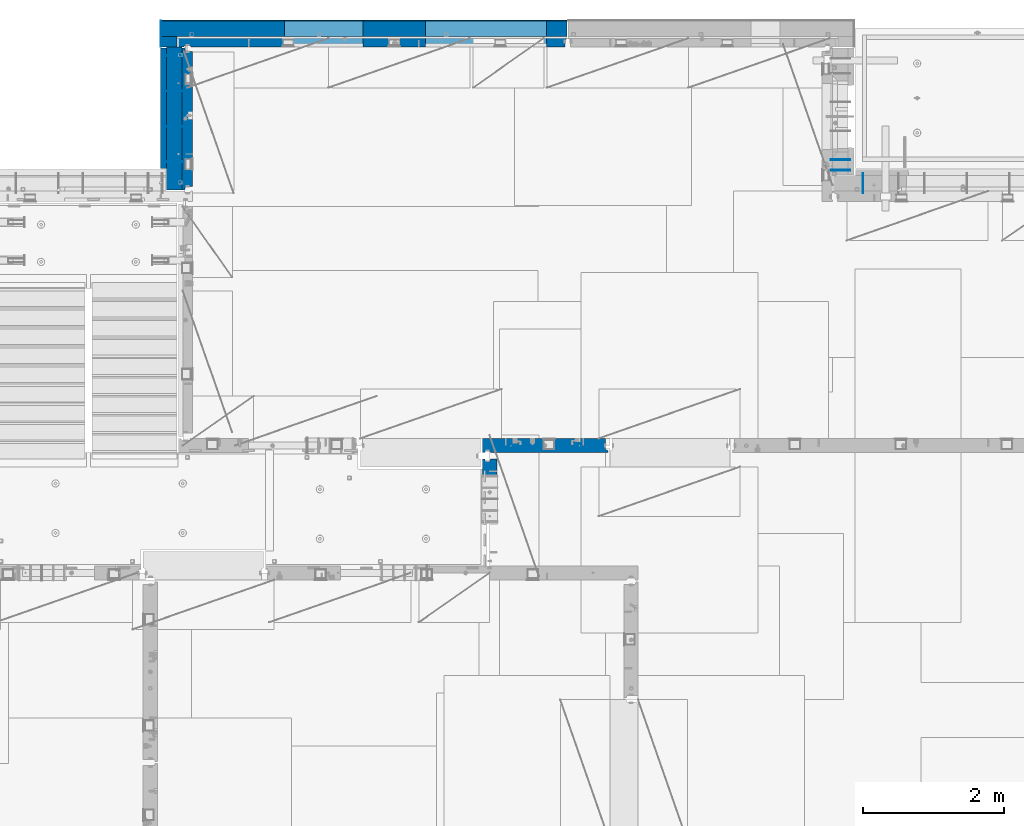
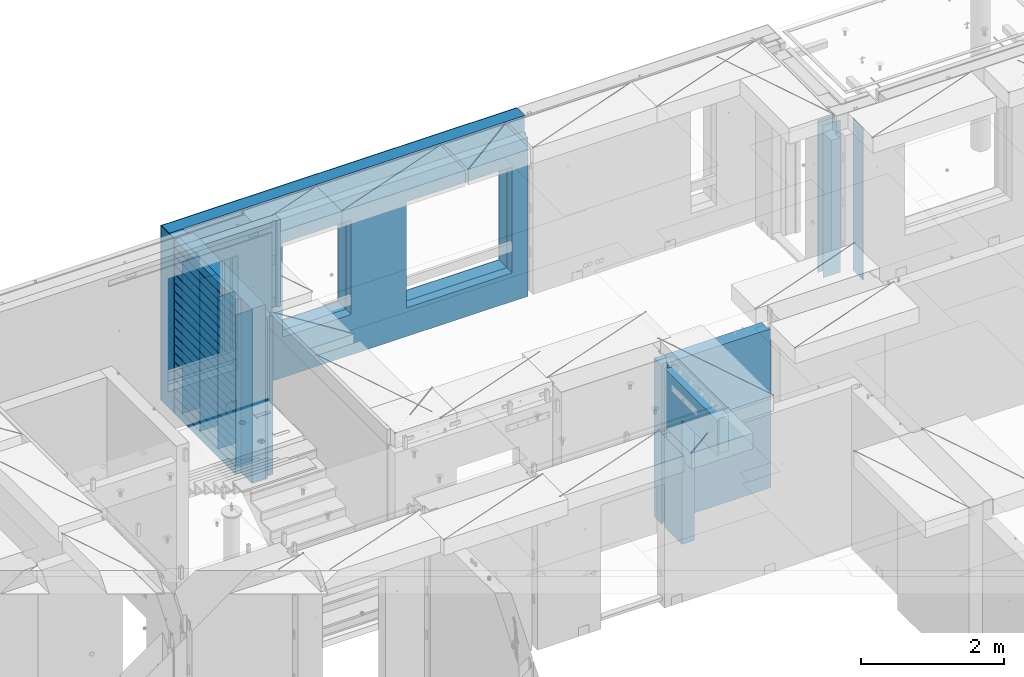
# One storey, part 239 of 349: 17 walls, 6 elements without a shape of their own.
"""IFC2X3 building model written with IfcOpenShell, lengths in millimetres."""

from ifc_helpers import new_model, si_unit, frame, origin_with_axes, place, context, subcontext, project, spatial, faceted_brep, material, type_object, element, aggregate, save


model = new_model("IFC2X3")

# Units and contexts
model_context = context("Model", 3, precision=1e-05, world=origin_with_axes())
body_context = subcontext(model_context, "Body", "Model", "MODEL_VIEW")
ifc_project = project(units=[si_unit("LENGTHUNIT", "METRE", prefix="MILLI"), si_unit("AREAUNIT", "SQUARE_METRE"), si_unit("VOLUMEUNIT", "CUBIC_METRE"), si_unit("MASSUNIT", "GRAM", prefix="KILO"), si_unit("TIMEUNIT", "SECOND"), si_unit("PLANEANGLEUNIT", "RADIAN"), si_unit("SOLIDANGLEUNIT", "STERADIAN"), si_unit("THERMODYNAMICTEMPERATUREUNIT", "DEGREE_CELSIUS"), si_unit("LUMINOUSINTENSITYUNIT", "LUMEN")], contexts=[model_context])

# Site, building, storey
site_placement = place(None, origin_with_axes())
site = spatial("IfcSite", under=ifc_project, at=site_placement, CompositionType="ELEMENT")
building_placement = place(site_placement, origin_with_axes())
building = spatial("IfcBuilding", under=site, at=building_placement, CompositionType="ELEMENT")
storey_placement = place(building_placement, origin_with_axes())
storey = spatial("IfcBuildingStorey", under=building, at=storey_placement, Name="4", CompositionType="ELEMENT", Elevation=0.0)

# Assembly, walls
assembly_1_placement = place(storey_placement, origin_with_axes())
assembly_1 = element("IfcElementAssembly", 1, at=assembly_1_placement, inside=storey, AssemblyPlace="NOTDEFINED", PredefinedType="REINFORCEMENT_UNIT")
ifc_material_1 = material(Name="Undefined")
wall_type_1 = type_object("IfcWallType", PredefinedType="NOTDEFINED")
wall_1_placement = place(assembly_1_placement, frame((22290.0, 22495.0, 92110.0), z_axis=(0.0, 0.0, 1.0), x_axis=(-1.0, 3.00000001838171e-08, 0.0)))
wall_1 = element("IfcWall", 2, at=wall_1_placement, type_object=wall_type_1, material=ifc_material_1, Name="(PD)", context=body_context, shape_type="Brep", body=[
    faceted_brep([(0.0, 5.0, -1300.0), (0.0, 5.0, 1300.0), (280.0, 5.0, 1300.0), (280.0, 5.0, -1300.0), (0.0, -5.0, 1300.0), (280.0, -5.0, 1300.0), (0.0, -5.0, -1300.0), (280.0, -5.0, -1300.0)], [[[0, 1, 2, 3]], [[1, 4, 5, 2]], [[4, 6, 7, 5]], [[6, 0, 3, 7]], [[5, 7, 3, 2]], [[6, 4, 1, 0]]]),
])
wall_2_placement = place(assembly_1_placement, frame((22290.0, 21995.0, 92110.0), z_axis=(0.0, 0.0, 1.0), x_axis=(-1.0, 3.00000001838171e-08, 0.0)))
wall_2 = element("IfcWall", 3, at=wall_2_placement, type_object=wall_type_1, material=ifc_material_1, Name="(PD)", context=body_context, shape_type="Brep", body=[
    faceted_brep([(0.0, 5.0, -1300.0), (0.0, 5.0, 1300.0), (280.0, 5.0, 1300.0), (280.0, 5.0, -1300.0), (0.0, -5.0, 1300.0), (280.0, -5.0, 1300.0), (0.0, -5.0, -1300.0), (280.0, -5.0, -1300.0)], [[[0, 1, 2, 3]], [[1, 4, 5, 2]], [[4, 6, 7, 5]], [[6, 0, 3, 7]], [[5, 7, 3, 2]], [[6, 4, 1, 0]]]),
])
wall_3_placement = place(assembly_1_placement, frame((22290.0, 21495.0, 92110.0), z_axis=(0.0, 0.0, 1.0), x_axis=(-1.0, 3.00000001838171e-08, 0.0)))
wall_3 = element("IfcWall", 4, at=wall_3_placement, type_object=wall_type_1, material=ifc_material_1, Name="(PD)", context=body_context, shape_type="Brep", body=[
    faceted_brep([(0.0, 5.0, -1300.0), (0.0, 5.0, 1300.0), (280.0, 5.0, 1300.0), (280.0, 5.0, -1300.0), (0.0, -5.0, 1300.0), (280.0, -5.0, 1300.0), (0.0, -5.0, -1300.0), (280.0, -5.0, -1300.0)], [[[0, 1, 2, 3]], [[1, 4, 5, 2]], [[4, 6, 7, 5]], [[6, 0, 3, 7]], [[5, 7, 3, 2]], [[6, 4, 1, 0]]]),
])

# Assembly, wall
assembly_2_placement = place(storey_placement, origin_with_axes())
assembly_2 = element("IfcElementAssembly", 5, at=assembly_2_placement, inside=storey, AssemblyPlace="NOTDEFINED", PredefinedType="REINFORCEMENT_UNIT")
wall_4_placement = place(assembly_2_placement, frame((31890.0, 20549.9951872276, 92115.0), z_axis=(0.0, 0.0, 1.0), x_axis=(0.0, 1.0, 0.0)))
wall_4 = element("IfcWall", 6, at=wall_4_placement, type_object=wall_type_1, material=ifc_material_1, Name="(PD)", context=body_context, shape_type="Brep", body=[
    faceted_brep([(0.0, 5.0, -1300.0), (0.0, 5.0, 1300.0), (280.0, 5.0, 1300.0), (280.0, 5.0, -1300.0), (0.0, -5.0, 1300.0), (280.0, -5.0, 1300.0), (0.0, -5.0, -1300.0), (280.0, -5.0, -1300.0)], [[[0, 1, 2, 3]], [[1, 4, 5, 2]], [[4, 6, 7, 5]], [[6, 0, 3, 7]], [[5, 7, 3, 2]], [[6, 4, 1, 0]]]),
])
aggregate(assembly_2, [wall_4])

# Assembly, walls
assembly_3_placement = place(storey_placement, origin_with_axes())
assembly_3 = element("IfcElementAssembly", 7, at=assembly_3_placement, inside=storey, AssemblyPlace="NOTDEFINED", PredefinedType="REINFORCEMENT_UNIT")
wall_5_placement = place(assembly_3_placement, frame((31429.9951872276, 20875.0, 92115.0), z_axis=(0.0, 0.0, 1.0), x_axis=(1.0, 0.0, 0.0)))
wall_5 = element("IfcWall", 8, at=wall_5_placement, type_object=wall_type_1, material=ifc_material_1, Name="(PD)", context=body_context, shape_type="Brep", body=[
    faceted_brep([(0.0, 5.0, -1300.0), (0.0, 5.0, 1300.0), (280.0, 5.0, 1300.0), (280.0, 5.0, -1300.0), (0.0, -5.0, 1300.0), (280.0, -5.0, 1300.0), (0.0, -5.0, -1300.0), (280.0, -5.0, -1300.0)], [[[0, 1, 2, 3]], [[1, 4, 5, 2]], [[4, 6, 7, 5]], [[6, 0, 3, 7]], [[5, 7, 3, 2]], [[6, 4, 1, 0]]]),
])
wall_6_placement = place(assembly_3_placement, frame((31429.9951872276, 21025.0, 92115.0), z_axis=(0.0, 0.0, 1.0), x_axis=(1.0, 0.0, 0.0)))
wall_6 = element("IfcWall", 9, at=wall_6_placement, type_object=wall_type_1, material=ifc_material_1, Name="(PD)", context=body_context, shape_type="Brep", body=[
    faceted_brep([(0.0, 5.0, -1300.0), (0.0, 5.0, 1300.0), (280.0, 5.0, 1300.0), (280.0, 5.0, -1300.0), (0.0, -5.0, 1300.0), (280.0, -5.0, 1300.0), (0.0, -5.0, -1300.0), (280.0, -5.0, -1300.0)], [[[0, 1, 2, 3]], [[1, 4, 5, 2]], [[4, 6, 7, 5]], [[6, 0, 3, 7]], [[5, 7, 3, 2]], [[6, 4, 1, 0]]]),
])
aggregate(assembly_3, [wall_5, wall_6])

# Wall
wall_7_placement = place(assembly_1_placement, frame((22290.0, 20995.0, 92110.0), z_axis=(0.0, 0.0, 1.0), x_axis=(-1.0, 3.00000001838171e-08, 0.0)))
wall_7 = element("IfcWall", 10, at=wall_7_placement, type_object=wall_type_1, material=ifc_material_1, Name="(PD)", context=body_context, shape_type="Brep", body=[
    faceted_brep([(0.0, 5.0, -1300.0), (0.0, 5.0, 1300.0), (280.0, 5.0, 1300.0), (280.0, 5.0, -1300.0), (0.0, -5.0, 1300.0), (280.0, -5.0, 1300.0), (0.0, -5.0, -1300.0), (280.0, -5.0, -1300.0)], [[[0, 1, 2, 3]], [[1, 4, 5, 2]], [[4, 6, 7, 5]], [[6, 0, 3, 7]], [[5, 7, 3, 2]], [[6, 4, 1, 0]]]),
])

# Assembly, wall
assembly_4_placement = place(storey_placement, origin_with_axes())
assembly_4 = element("IfcElementAssembly", 11, at=assembly_4_placement, inside=storey, AssemblyPlace="NOTDEFINED", PredefinedType="REINFORCEMENT_UNIT")
ifc_material_2 = material(Name="CONCRETE/C25/30")
wall_type_2 = type_object("IfcWallType", PredefinedType="NOTDEFINED")
wall_8_placement = place(assembly_4_placement, frame((26510.0014364077, 16980.0, 92112.5), z_axis=(0.0, 0.0, 1.0), x_axis=(1.0, 0.0, 0.0)))
wall_8 = element("IfcWall", 12, at=wall_8_placement, type_object=wall_type_2, material=ifc_material_2, context=body_context, shape_type="Brep", body=[
    faceted_brep([(1739.99847412109, 100.0, 1357.5), (1739.99847412109, -57.0, 1357.5), (1739.99847412109, -57.0, -1357.5), (1739.99847412109, 100.0, -1357.5), (1769.99847412109, -70.0, 1357.5), (1769.99847412109, -70.0, -1357.5), (0.0, -100.0, -1357.5), (0.0, -100.0, 1357.5), (0.0, 100.0, 1357.5), (0.0, 100.0, -1357.5), (29.998563592264, -100.0, -1357.5), (29.998563592264, -100.0, 1357.5), (29.998563592264, -80.0008544921875, -1357.5), (29.998563592264, -80.0008544921875, 1357.5), (109.998563592264, -80.0008544921875, -1357.5), (109.998563592264, -80.0008544921875, 1357.5), (109.998563592264, -100.0, -1357.5), (109.998563592264, -100.0, 1357.5), (1769.99847412109, -100.0, -1357.5), (1769.99847412109, -100.0, 1357.5)], [[[0, 1, 2, 3]], [[4, 5, 2, 1]], [[6, 7, 8, 9]], [[7, 6, 10, 11]], [[11, 10, 12, 13]], [[13, 12, 14, 15]], [[15, 14, 16, 17]], [[18, 19, 17, 16]], [[0, 8, 7, 11, 13, 15, 17, 19, 4, 1]], [[9, 8, 0, 3]], [[18, 16, 14, 12, 10, 6, 9, 3, 2, 5]], [[19, 18, 5, 4]]]),
])
aggregate(assembly_4, [wall_8])

assembly_5_placement = place(storey_placement, origin_with_axes())
assembly_5 = element("IfcElementAssembly", 13, at=assembly_5_placement, inside=storey, AssemblyPlace="NOTDEFINED", PredefinedType="REINFORCEMENT_UNIT")
wall_9_placement = place(assembly_5_placement, frame((26609.9991475894, 15280.0004107749, 92112.5), z_axis=(0.0, 0.0, 1.0), x_axis=(0.0, 1.0, 0.0)))
wall_9 = element("IfcWall", 14, at=wall_9_placement, type_object=wall_type_2, material=ifc_material_2, context=body_context, shape_type="Brep", body=[
    faceted_brep([(1509.99949975397, 70.0, 1357.5), (1489.99949975397, 70.0, 1357.5), (1489.99949975397, 70.0, -1357.5), (1509.99949975397, 70.0, -1357.5), (1489.99949975397, -10.0, 1357.5), (1489.99949975397, -10.0, -1357.5), (1509.99949975397, -10.0, 1357.5), (1509.99949975397, -10.0, -1357.5), (29.9995892251427, 70.0, 1357.5), (29.9995892251427, 70.0, 762.5), (59.9995892251427, 57.0, 762.5), (59.9995892251427, 57.0, 1357.5), (29.9995892251427, 100.0, 1357.5), (29.9995892251427, 100.0, 762.5), (1509.99949975397, 100.0, 1357.5), (1509.99949975397, 100.0, -1357.5), (1019.99979369292, 100.0, -1357.5), (1019.99979369292, 100.0, 762.5), (1019.99979369292, -100.0, 762.5), (1019.99979369292, -100.0, -1357.5), (59.9995892251427, -100.0, 762.5), (59.9995892251427, -100.0, 1357.5), (1509.99949975397, -100.0, -1357.5), (1509.99949975397, -100.0, 1357.5)], [[[0, 1, 2, 3]], [[4, 5, 2, 1]], [[6, 7, 5, 4]], [[8, 9, 10, 11]], [[12, 13, 9, 8]], [[12, 14, 15, 16, 17, 13]], [[18, 17, 16, 19]], [[9, 13, 17, 18, 20, 10]], [[21, 11, 10, 20]], [[18, 19, 22, 23, 21, 20]], [[1, 0, 14, 12, 8, 11, 21, 23, 6, 4]], [[15, 14, 0, 3]], [[22, 19, 16, 15, 3, 2, 5, 7]], [[23, 22, 7, 6]]]),
])
aggregate(assembly_5, [wall_9])

# Wall
ifc_material_3 = material(Name="COS5gt")
wall_type_3 = type_object("IfcWallType", PredefinedType="NOTDEFINED")
wall_10_placement = place(assembly_1_placement, frame((22150.0, 20595.0, 92247.5), z_axis=(0.0, 0.0, 1.0), x_axis=(0.0, 1.0, 0.0)))
wall_10 = element("IfcWall", 15, at=wall_10_placement, type_object=wall_type_3, material=ifc_material_3, context=body_context, shape_type="Brep", body=[
    faceted_brep([(0.0, 110.0, -1492.5), (0.0, 110.0, 1492.5), (2025.0, 110.0, 1492.5), (2025.0, 110.0, -1492.5), (0.0, -110.0, 1492.5), (2025.0, -110.0, 1492.5), (0.0, -110.0, -1492.5), (2025.0, -110.0, -1492.5)], [[[0, 1, 2, 3]], [[1, 4, 5, 2]], [[4, 6, 7, 5]], [[6, 0, 3, 7]], [[5, 7, 3, 2]], [[6, 4, 1, 0]]]),
])

# Assembly, walls
assembly_6_placement = place(storey_placement, origin_with_axes())
assembly_6 = element("IfcElementAssembly", 16, at=assembly_6_placement, inside=storey, AssemblyPlace="NOTDEFINED", PredefinedType="REINFORCEMENT_UNIT")
ifc_material_4 = material()
wall_11_placement = place(assembly_6_placement, frame((22075.0, 22620.0, 92247.5), z_axis=(0.0, 0.0, 1.0), x_axis=(0.0, 1.0, 0.0)))
wall_11 = element("IfcWall", 17, at=wall_11_placement, type_object=wall_type_3, material=ifc_material_4, context=body_context, shape_type="Brep", body=[
    faceted_brep([(0.0, 110.0, -1492.5), (0.0, 110.0, 1492.5), (150.0, 110.0, 1492.5), (150.0, 110.0, -1492.5), (0.0, -110.0, 1492.5), (150.0, -110.0, 1492.5), (0.0, -110.0, -1492.5), (150.0, -110.0, -1492.5)], [[[0, 1, 2, 3]], [[1, 4, 5, 2]], [[4, 6, 7, 5]], [[6, 0, 3, 7]], [[5, 7, 3, 2]], [[6, 4, 1, 0]]]),
])
wall_12_placement = place(assembly_6_placement, frame((22260.0, 22880.0, 92247.5), z_axis=(0.0, 0.0, 1.0), x_axis=(1.0, 0.0, 0.0)))
wall_12 = element("IfcWall", 18, at=wall_12_placement, type_object=wall_type_3, material=ifc_material_4, context=body_context, shape_type="Brep", body=[
    faceted_brep([(-295.0, 110.0, 1492.5), (-295.0, -110.0, 1492.5), (5445.0, -110.0, 1492.5), (5445.0, 110.0, 1492.5), (-295.0, -110.0, -1492.5), (-295.0, 110.0, -1492.5), (5445.0, 110.0, -1492.5), (5445.0, -110.0, -1492.5), (3445.00100868184, 110.0, -1002.5), (5155.00100868184, 110.0, -1002.5), (5155.00100868184, 110.0, 807.5), (3445.00100868184, 110.0, 807.5), (1444.99910133321, 110.0, -802.5), (2554.99910133321, 110.0, -802.5), (2554.99910133321, 110.0, 807.5), (1444.99910133321, 110.0, 807.5), (1444.99910133321, -110.0, -802.5), (2554.99910133321, -110.0, -802.5), (1444.99910133321, -110.0, 807.5), (2554.99910133321, -110.0, 807.5), (3445.00100868184, -110.0, -1002.5), (3445.00100868184, -110.0, 807.5), (5155.00100868184, -110.0, 807.5), (5155.00100868184, -110.0, -1002.5)], [[[0, 1, 2, 3]], [[4, 1, 0, 5]], [[4, 5, 6, 7]], [[2, 7, 6, 3]], [[5, 0, 3, 6], [8, 9, 10, 11], [12, 13, 14, 15]], [[12, 16, 17, 13]], [[15, 18, 16, 12]], [[14, 19, 18, 15]], [[13, 17, 19, 14]], [[1, 4, 7, 2], [20, 21, 22, 23], [16, 18, 19, 17]], [[10, 22, 21, 11]], [[9, 23, 22, 10]], [[8, 20, 23, 9]], [[11, 21, 20, 8]]]),
])

# Wall
ifc_material_5 = material(Name="CONCRETE/C30/37")
wall_type_4 = type_object("IfcWallType", PredefinedType="NOTDEFINED")
wall_13_placement = place(assembly_1_placement, frame((21997.5, 20900.0, 92247.5), z_axis=(0.0, 0.0, 1.0), x_axis=(0.0, 1.0, 0.0)))
wall_13 = element("IfcWall", 19, at=wall_13_placement, type_object=wall_type_4, material=ifc_material_5, context=body_context, shape_type="Brep", body=[
    faceted_brep([(1705.0, 42.5, -1357.0), (0.0, 42.5, -1357.00000005524), (0.0, 32.4999992507037, -1355.00000000074), (1705.0, 32.5, -1355.0), (1705.0, 32.5, -1345.0), (0.0, 32.4999991127006, -1344.99999959956), (0.0, 42.5, -1343.00000011075), (1705.0, 42.5, -1343.0), (0.0, -42.5, -1492.5), (0.0, 42.5, -1492.5), (1705.0, 42.5, -1492.5), (1705.0, -42.5, -1492.5), (0.0, -42.5, 1492.5), (1705.0, -42.5, 1492.5), (0.0, 42.5, 1492.5), (1705.0, 42.5, 1492.5), (1705.0, 42.5, 1357.0), (0.0, 42.5, 1356.99999988925), (1705.0, 32.5, 1355.0), (-3.63797880709171e-12, 32.4999991127006, 1355.00000040044), (1705.0, 32.5, 1345.0), (-3.63797880709171e-12, 32.4999992507037, 1344.99999999926), (1705.0, 42.5, 1343.0), (0.0, 42.5, 1342.99999994476), (1705.0, 42.5, 1207.0), (0.0, 42.5, 1206.99999988925), (1705.0, 32.5, 1205.0), (0.0, 32.4999991127006, 1205.00000040044), (1705.0, 32.5, 1195.0), (0.0, 32.4999992507037, 1194.99999999926), (1705.0, 42.5, 1193.0), (0.0, 42.5, 1192.99999994476), (1705.0, 42.5, 1057.0), (0.0, 42.5, 1056.99999988925), (1705.0, 32.5, 1055.0), (0.0, 32.4999991127006, 1055.00000040044), (1705.0, 32.5, 1045.0), (0.0, 32.4999992507037, 1044.99999999926), (1705.0, 42.5, 1043.0), (0.0, 42.5, 1042.99999994476), (1705.0, 42.5, 907.0), (0.0, 42.5, 906.999999889245), (1705.0, 32.5, 905.0), (0.0, 32.4999991127006, 905.00000040044), (1705.0, 32.5, 895.0), (0.0, 32.4999992507037, 894.999999999258), (1705.0, 42.5, 893.0), (0.0, 42.5, 892.999999944761), (1705.0, 42.5, 757.0), (0.0, 42.5, 756.999999889245), (1705.0, 32.5, 755.0), (0.0, 32.4999991127006, 755.00000040044), (1705.0, 32.5, 745.0), (0.0, 32.4999992507037, 744.999999999258), (1705.0, 42.5, 743.0), (0.0, 42.5, 742.999999944761), (1705.0, 42.5, 607.0), (0.0, 42.5, 606.999999889245), (1705.0, 32.5, 605.0), (3.63797880709171e-12, 32.4999991127006, 605.00000040044), (1705.0, 32.5, 595.0), (3.63797880709171e-12, 32.4999992507037, 594.999999999258), (1705.0, 42.5, 593.0), (0.0, 42.5, 592.999999944761), (1705.0, 42.5, 457.0), (0.0, 42.5, 456.999999889245), (1705.0, 32.5, 455.0), (0.0, 32.4999991127006, 455.00000040044), (1705.0, 32.5, 445.0), (0.0, 32.4999992507037, 444.999999999258), (1705.0, 42.5, 443.0), (0.0, 42.5, 442.999999944761), (1705.0, 42.5, 307.0), (0.0, 42.5, 306.999999889245), (1705.0, 32.5, 305.0), (-3.63797880709171e-12, 32.4999991127006, 305.00000040044), (1705.0, 32.5, 295.0), (-3.63797880709171e-12, 32.4999992507037, 294.999999999258), (1705.0, 42.5, 293.0), (0.0, 42.5, 292.999999944761), (1705.0, 42.5, 157.0), (0.0, 42.5, 156.999999889245), (1705.0, 32.5, 155.0), (-3.63797880709171e-12, 32.4999991127006, 155.00000040044), (1705.0, 32.5, 145.0), (-3.63797880709171e-12, 32.4999992507037, 144.999999999258), (1705.0, 42.5, 143.0), (0.0, 42.5, 142.999999944761), (1705.0, 42.5, 7.0), (0.0, 42.5, 6.99999988924537), (1705.0, 32.5, 5.0), (0.0, 32.4999991127006, 5.0000004004396), (1705.0, 32.5, -5.0), (0.0, 32.4999992507037, -5.00000000074215), (1705.0, 42.5, -7.0), (0.0, 42.5, -7.00000005523907), (1705.0, 42.5, -143.0), (0.0, 42.5, -143.000000110755), (1705.0, 32.5, -145.0), (3.63797880709171e-12, 32.4999991127006, -144.99999959956), (1705.0, 32.5, -155.0), (3.63797880709171e-12, 32.4999992507037, -155.000000000742), (1705.0, 42.5, -157.0), (0.0, 42.5, -157.000000055239), (1705.0, 42.5, -293.0), (0.0, 42.5, -293.000000110755), (1705.0, 32.5, -295.0), (0.0, 32.4999991127006, -294.99999959956), (1705.0, 32.5, -305.0), (0.0, 32.4999992507037, -305.000000000742), (1705.0, 42.5, -307.0), (0.0, 42.5, -307.000000055239), (1705.0, 42.5, -443.0), (0.0, 42.5, -443.000000110755), (1705.0, 32.5, -445.0), (0.0, 32.4999991127006, -444.99999959956), (1705.0, 32.5, -455.0), (0.0, 32.4999992507037, -455.000000000742), (1705.0, 42.5, -457.0), (0.0, 42.5, -457.000000055239), (1705.0, 42.5, -593.0), (0.0, 42.5, -593.000000110755), (1705.0, 32.5, -595.0), (3.63797880709171e-12, 32.4999991127006, -594.99999959956), (1705.0, 32.5, -605.0), (3.63797880709171e-12, 32.4999992507037, -605.000000000742), (1705.0, 42.5, -607.0), (0.0, 42.5, -607.000000055239), (1705.0, 42.5, -743.0), (0.0, 42.5, -743.000000110755), (1705.0, 32.5, -745.0), (0.0, 32.4999991127006, -744.99999959956), (1705.0, 32.5, -755.0), (0.0, 32.4999992507037, -755.000000000742), (1705.0, 42.5, -757.0), (0.0, 42.5, -757.000000055239), (1705.0, 42.5, -893.0), (0.0, 42.5, -893.000000110755), (1705.0, 32.5, -895.0), (0.0, 32.4999991127006, -894.99999959956), (1705.0, 32.5, -905.0), (0.0, 32.4999992507037, -905.000000000742), (1705.0, 42.5, -907.0), (0.0, 42.5, -907.000000055239), (1705.0, 42.5, -1043.0), (0.0, 42.5, -1043.00000011075), (1705.0, 32.5, -1045.0), (0.0, 32.4999991127006, -1044.99999959956), (1705.0, 32.5, -1055.0), (0.0, 32.4999992507037, -1055.00000000074), (1705.0, 42.5, -1057.0), (0.0, 42.5, -1057.00000005524), (1705.0, 42.5, -1193.0), (0.0, 42.5, -1193.00000011075), (1705.0, 32.5, -1195.0), (0.0, 32.4999991127006, -1194.99999959956), (1705.0, 32.5, -1205.0), (0.0, 32.4999992507037, -1205.00000000074), (1705.0, 42.5, -1207.0), (0.0, 42.5, -1207.00000005524)], [[[0, 1, 2, 3]], [[4, 5, 6, 7]], [[3, 2, 5, 4]], [[8, 9, 10, 11]], [[12, 8, 11, 13]], [[14, 12, 13, 15]], [[14, 15, 16, 17]], [[18, 19, 17, 16]], [[20, 21, 19, 18]], [[22, 23, 21, 20]], [[24, 25, 23, 22]], [[26, 27, 25, 24]], [[28, 29, 27, 26]], [[30, 31, 29, 28]], [[32, 33, 31, 30]], [[34, 35, 33, 32]], [[36, 37, 35, 34]], [[38, 39, 37, 36]], [[40, 41, 39, 38]], [[42, 43, 41, 40]], [[44, 45, 43, 42]], [[46, 47, 45, 44]], [[48, 49, 47, 46]], [[50, 51, 49, 48]], [[52, 53, 51, 50]], [[54, 55, 53, 52]], [[56, 57, 55, 54]], [[58, 59, 57, 56]], [[60, 61, 59, 58]], [[62, 63, 61, 60]], [[64, 65, 63, 62]], [[66, 67, 65, 64]], [[68, 69, 67, 66]], [[70, 71, 69, 68]], [[72, 73, 71, 70]], [[74, 75, 73, 72]], [[76, 77, 75, 74]], [[78, 79, 77, 76]], [[80, 81, 79, 78]], [[82, 83, 81, 80]], [[84, 85, 83, 82]], [[86, 87, 85, 84]], [[88, 89, 87, 86]], [[90, 91, 89, 88]], [[92, 93, 91, 90]], [[94, 95, 93, 92]], [[96, 97, 95, 94]], [[98, 99, 97, 96]], [[100, 101, 99, 98]], [[102, 103, 101, 100]], [[104, 105, 103, 102]], [[106, 107, 105, 104]], [[108, 109, 107, 106]], [[110, 111, 109, 108]], [[112, 113, 111, 110]], [[114, 115, 113, 112]], [[116, 117, 115, 114]], [[118, 119, 117, 116]], [[120, 121, 119, 118]], [[122, 123, 121, 120]], [[124, 125, 123, 122]], [[126, 127, 125, 124]], [[128, 129, 127, 126]], [[130, 131, 129, 128]], [[132, 133, 131, 130]], [[134, 135, 133, 132]], [[136, 137, 135, 134]], [[138, 139, 137, 136]], [[140, 141, 139, 138]], [[142, 143, 141, 140]], [[144, 145, 143, 142]], [[146, 147, 145, 144]], [[148, 149, 147, 146]], [[150, 151, 149, 148]], [[152, 153, 151, 150]], [[154, 155, 153, 152]], [[156, 157, 155, 154]], [[158, 159, 157, 156]], [[7, 6, 159, 158]], [[21, 23, 25, 27, 29, 31, 33, 35, 37, 39, 41, 43, 45, 47, 49, 51, 53, 55, 57, 59, 61, 63, 65, 67, 69, 71, 73, 75, 77, 79, 81, 83, 85, 87, 89, 91, 93, 95, 97, 99, 101, 103, 105, 107, 109, 111, 113, 115, 117, 119, 121, 123, 125, 127, 129, 131, 133, 135, 137, 139, 141, 143, 145, 147, 149, 151, 153, 155, 157, 159, 6, 5, 2, 1, 9, 8, 12, 14, 17, 19]], [[10, 9, 1, 0]], [[15, 13, 11, 10, 0, 3, 4, 7, 158, 156, 154, 152, 150, 148, 146, 144, 142, 140, 138, 136, 134, 132, 130, 128, 126, 124, 122, 120, 118, 116, 114, 112, 110, 108, 106, 104, 102, 100, 98, 96, 94, 92, 90, 88, 86, 84, 82, 80, 78, 76, 74, 72, 70, 68, 66, 64, 62, 60, 58, 56, 54, 52, 50, 48, 46, 44, 42, 40, 38, 36, 34, 32, 30, 28, 26, 24, 22, 20, 18, 16]]]),
])

wall_type_5 = type_object("IfcWallType", PredefinedType="NOTDEFINED")
wall_14_placement = place(assembly_6_placement, frame((22185.0, 22695.0, 92112.5), z_axis=(0.0, 0.0, 1.0), x_axis=(1.0, 0.0, 0.0)))
wall_14 = element("IfcWall", 20, at=wall_14_placement, type_object=wall_type_5, material=ifc_material_2, context=body_context, shape_type="Brep", body=[
    faceted_brep([(3520.00100868184, 75.0, 942.5), (3520.00100868184, -75.0000008199713, 942.5), (3520.00100868184, -75.0000000602631, -867.5), (3520.00100868184, 75.0, -867.5), (5230.00100868184, -74.9999996918959, -867.5), (5230.00100868184, 75.0, -867.5), (5230.00100868184, -75.0000004516041, 942.5), (5230.00100868184, 75.0, 942.5), (5490.0, -75.0, 1357.5), (5490.0, -75.0, -1357.5), (5490.0, 24.9999980926514, -1357.5), (5490.0, 24.9999980926514, 1357.5), (5520.0, 45.0, 1357.5), (5520.0, 75.0, 1357.5), (0.0, 75.0, 1357.5), (0.0, -75.0, 1357.5), (100.0, -75.0, 1357.5), (110.0, -55.0000022791319, 1357.5), (190.0, -55.0000022791319, 1357.5), (200.0, -75.0000022791319, 1357.5), (0.0, -75.0, -1357.5), (0.0, 75.0, -1357.5), (100.0, -75.0, -1357.5), (110.0, -55.0000022791319, -1357.5), (190.0, -55.0000022791319, -1357.5), (200.0, -75.0, -1357.5), (5520.0, 75.0, -1357.5), (5520.0, 45.0, -1357.5), (1519.99910133321, 75.0, -667.5), (2629.99910133321, 75.0, -667.5), (2629.99910133321, 75.0, 942.5), (1519.99910133321, 75.0, 942.5), (1519.99910133321, -75.0000005750444, -667.5), (2629.99910133321, -75.0000003359273, -667.5), (1519.99910133321, -75.0000012508099, 942.5), (2629.99910133321, -75.0000010116928, 942.5)], [[[0, 1, 2, 3]], [[3, 2, 4, 5]], [[5, 4, 6, 7]], [[7, 6, 1, 0]], [[8, 9, 10, 11]], [[8, 11, 12, 13, 14, 15, 16, 17, 18, 19]], [[20, 15, 14, 21]], [[15, 20, 22, 16]], [[16, 22, 23, 17]], [[17, 23, 24, 18]], [[19, 18, 24, 25]], [[23, 22, 20, 21, 26, 27, 10, 9, 25, 24]], [[12, 11, 10, 27]], [[26, 13, 12, 27]], [[21, 14, 13, 26], [3, 5, 7, 0], [28, 29, 30, 31]], [[28, 32, 33, 29]], [[31, 34, 32, 28]], [[30, 35, 34, 31]], [[29, 33, 35, 30]], [[9, 8, 19, 25], [2, 1, 6, 4], [32, 34, 35, 33]]]),
])

wall_15_placement = place(assembly_1_placement, frame((22335.0, 20595.0, 92112.5), z_axis=(0.0, 0.0, 1.0), x_axis=(0.0, 1.0, 0.0)))
wall_15 = element("IfcWall", 21, at=wall_15_placement, type_object=wall_type_5, material=ifc_material_2, context=body_context, shape_type="Brep", body=[
    faceted_brep([(0.0, 40.0, 1357.5), (0.0, 40.0, -1357.5), (50.0, 27.0, -1357.5), (50.0, 27.0, 1357.5), (50.0, -75.0, 1357.5), (50.0, -75.0, -1357.5), (0.0, 75.0, -1357.5), (0.0, 75.0, 1357.5), (2009.99999772087, 75.0, 1357.5), (2009.99999772087, 75.0, -1357.5), (2009.99999772087, 40.0, 1357.5), (2009.99999772087, 40.0, -1357.5), (1959.99999772087, 27.0, 1357.5), (1959.99999772087, 27.0, -1357.5), (1959.99999772087, -75.0, 1357.5), (1959.99999772087, -75.0, -1357.5)], [[[0, 1, 2, 3]], [[4, 3, 2, 5]], [[6, 7, 8, 9]], [[9, 8, 10, 11]], [[12, 13, 11, 10]], [[14, 15, 13, 12]], [[15, 14, 4, 5]], [[1, 6, 9, 11, 13, 15, 5, 2]], [[7, 6, 1, 0]], [[14, 12, 10, 8, 7, 0, 3, 4]]]),
])

aggregate(assembly_1, [wall_10, wall_1, wall_2, wall_3, wall_7, wall_13, wall_15])

wall_type_6 = type_object("IfcWallType", PredefinedType="NOTDEFINED")
wall_16_placement = place(assembly_6_placement, frame((21960.0001313636, 22620.0, 92247.5), z_axis=(0.0, 0.0, 1.0), x_axis=(0.0, 1.0, 0.0)))
wall_16 = element("IfcWall", 22, at=wall_16_placement, type_object=wall_type_6, material=ifc_material_5, context=body_context, shape_type="Brep", body=[
    faceted_brep([(0.0, 5.0, -1492.5), (0.0, 5.0, 1492.5), (370.0, 5.0, 1492.5), (370.0, 5.0, -1492.5), (0.0, -5.0, 1492.5), (370.0, -5.0, 1492.5), (0.0, -5.0, -1492.5), (370.0, -5.0, -1492.5)], [[[0, 1, 2, 3]], [[1, 4, 5, 2]], [[4, 6, 7, 5]], [[6, 0, 3, 7]], [[5, 7, 3, 2]], [[6, 4, 1, 0]]]),
])

wall_17_placement = place(assembly_6_placement, frame((22260.0, 22995.0, 92247.5), z_axis=(0.0, 0.0, 1.0), x_axis=(1.0, 0.0, 0.0)))
wall_17 = element("IfcWall", 23, at=wall_17_placement, type_object=wall_type_6, material=ifc_material_5, context=body_context, shape_type="Brep", body=[
    faceted_brep([(-305.0, 5.0, 1492.5), (-305.0, -5.0, 1492.5), (5445.0, -5.0, 1492.5), (5445.0, 5.0, 1492.5), (-305.0, -5.0, -1492.5), (-305.0, 5.0, -1492.5), (5445.0, 5.0, -1492.5), (5445.0, -5.0, -1492.5), (3445.00100868184, 5.0, -1002.5), (5155.00100868184, 5.0, -1002.5), (5155.00100868184, 5.0, 807.5), (3445.00100868184, 5.0, 807.5), (1444.99910133321, 5.0, -802.5), (2554.99910133321, 5.0, -802.5), (2554.99910133321, 5.0, 807.5), (1444.99910133321, 5.0, 807.5), (1444.99910133321, -5.0, -802.5), (2554.99910133321, -5.0, -802.5), (1444.99910133321, -5.0, 807.5), (2554.99910133321, -5.0, 807.5), (3445.00100868184, -5.0, -1002.5), (3445.00100868184, -5.0, 807.5), (5155.00100868184, -5.0, 807.5), (5155.00100868184, -5.0, -1002.5)], [[[0, 1, 2, 3]], [[4, 1, 0, 5]], [[4, 5, 6, 7]], [[2, 7, 6, 3]], [[5, 0, 3, 6], [8, 9, 10, 11], [12, 13, 14, 15]], [[12, 16, 17, 13]], [[15, 18, 16, 12]], [[14, 19, 18, 15]], [[13, 17, 19, 14]], [[1, 4, 7, 2], [20, 21, 22, 23], [16, 18, 19, 17]], [[10, 22, 21, 11]], [[9, 23, 22, 10]], [[8, 20, 23, 9]], [[11, 21, 20, 8]]]),
])

aggregate(assembly_6, [wall_16, wall_11, wall_12, wall_17, wall_14])

save(model, "model.ifc")
